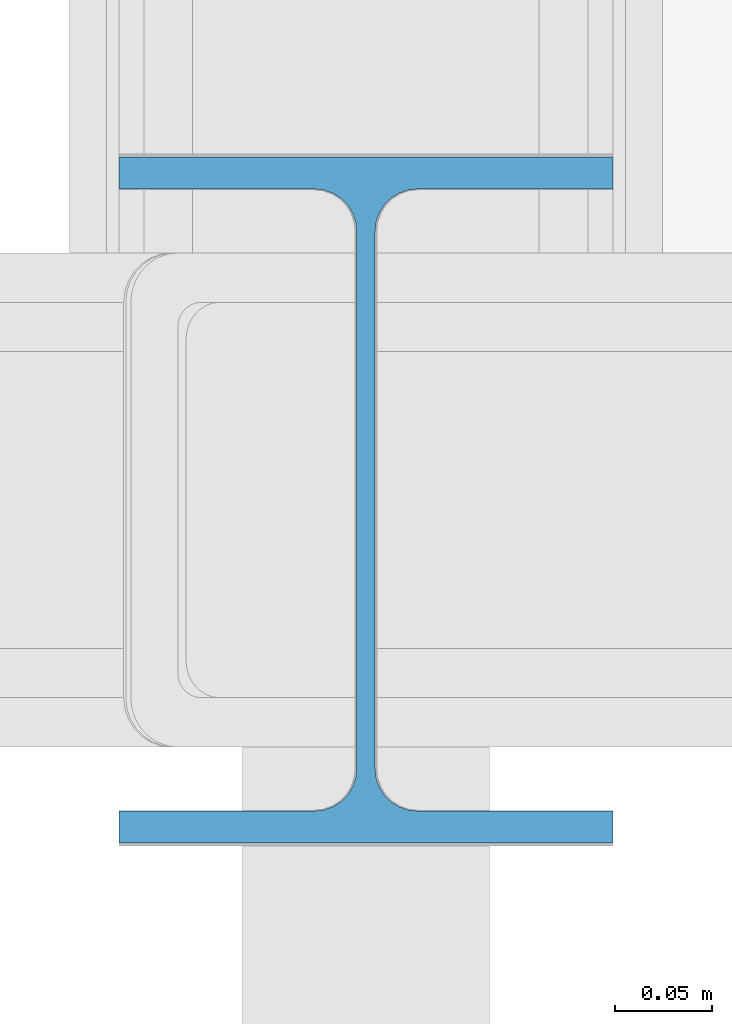
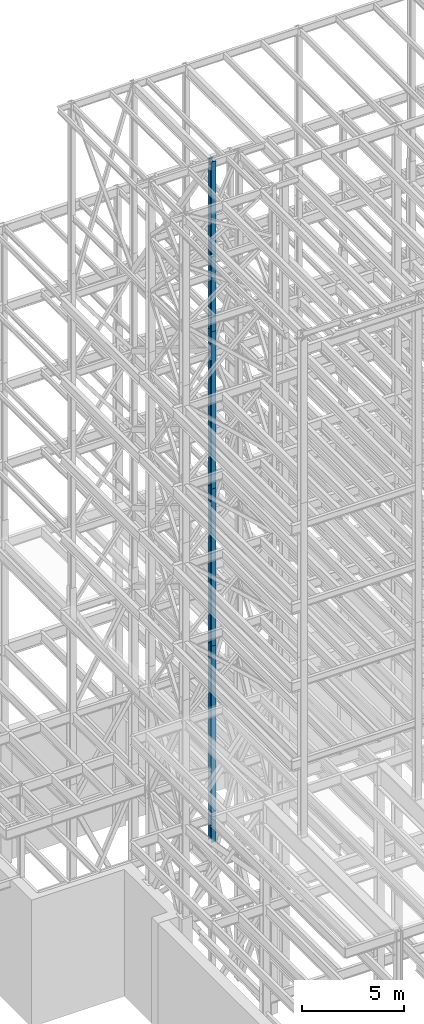
# One storey, part 15 of 150: 4 columns.
"""IFC2X3 building model written with IfcOpenShell, lengths in millimetres."""

from ifc_helpers import new_model, si_unit, frame, origin_with_axes, origin_2d_with_axis, place, context, subcontext, project, spatial, i_section, extrude, material, type_object, element, save


model = new_model("IFC2X3")

# Units and contexts
model_context = context("Model", 3, precision=1e-05, world=origin_with_axes())
body_context = subcontext(model_context, "Body", "Model", "MODEL_VIEW")
ifc_project = project(units=[si_unit("LENGTHUNIT", "METRE", prefix="MILLI"), si_unit("AREAUNIT", "SQUARE_METRE"), si_unit("VOLUMEUNIT", "CUBIC_METRE"), si_unit("MASSUNIT", "GRAM", prefix="KILO"), si_unit("TIMEUNIT", "SECOND"), si_unit("PLANEANGLEUNIT", "RADIAN"), si_unit("SOLIDANGLEUNIT", "STERADIAN"), si_unit("THERMODYNAMICTEMPERATUREUNIT", "DEGREE_CELSIUS"), si_unit("LUMINOUSINTENSITYUNIT", "LUMEN")], contexts=[model_context])

# Site, building, storey
site_placement = place(None, origin_with_axes())
site = spatial("IfcSite", under=ifc_project, at=site_placement, CompositionType="ELEMENT")
building_placement = place(site_placement, origin_with_axes())
building = spatial("IfcBuilding", under=site, at=building_placement, Name="Undefined", CompositionType="ELEMENT")
storey_placement = place(building_placement, origin_with_axes())
storey = spatial("IfcBuildingStorey", under=building, at=storey_placement, Name="Undefined", CompositionType="ELEMENT", Elevation=0.0)

# Columns
ifc_material = material(Name="STEEL/A992")
column_type = type_object("IfcColumnType", Name="W14X61", PredefinedType="NOTDEFINED")
column_1_placement = place(storey_placement, frame((8788.39949708, 24384.0, 55702.2), z_axis=(0.0, 0.0, 1.0), x_axis=(1.0, 0.0, 0.0)))
element("IfcColumn", 1, at=column_1_placement, inside=storey, type_object=column_type, material=ifc_material, Name="COLUMN", ObjectType="W14X61", context=body_context, shape_type="SweptSolid", body=[
    extrude(i_section(OverallWidth=254.0, OverallDepth=352.425, WebThickness=9.5249, FlangeThickness=16.383, FilletRadius=21.717, at=origin_2d_with_axis()), frame((0.0, 0.0, 10210.8), z_axis=(0.0, 0.0, -1.0), x_axis=(-1.0, 0.0, 0.0)), (0.0, 0.0, 1.0), 10210.8),
])
for number, where, z_axis, x_axis, name in (
    (2, (8788.39949708, 24384.0, 46253.4), (0.0, 0.0, 1.0), (1.0, 0.0, 0.0), "COLUMN"),
    (3, (8788.39949708, 24384.0, 36804.6), (0.0, 0.0, 1.0), (1.0, 0.0, 0.0), "COLUMN"),
):
    element("IfcColumn", number, at=place(storey_placement, frame(where, z_axis=z_axis, x_axis=x_axis)), inside=storey, type_object=column_type, material=ifc_material, Name=name, ObjectType="W14X61", context=body_context, shape_type="SweptSolid", body=[
        extrude(i_section(OverallWidth=254.0, OverallDepth=352.425, WebThickness=9.5249, FlangeThickness=16.383, FilletRadius=21.717, at=origin_2d_with_axis()), frame((0.0, 0.0, 9448.8), z_axis=(0.0, 0.0, -1.0), x_axis=(-1.0, 0.0, 0.0)), (0.0, 0.0, 1.0), 9448.8),
    ])
column_2_placement = place(storey_placement, frame((8788.39949708, 24384.0, 24993.6), z_axis=(0.0, 0.0, 1.0), x_axis=(1.0, 0.0, 0.0)))
element("IfcColumn", 4, at=column_2_placement, inside=storey, type_object=column_type, material=ifc_material, Name="COLUMN", ObjectType="W14X61", context=body_context, shape_type="SweptSolid", body=[
    extrude(i_section(OverallWidth=254.0, OverallDepth=352.425, WebThickness=9.5249, FlangeThickness=16.383, FilletRadius=21.717, at=origin_2d_with_axis()), frame((0.0, 0.0, 11811.0), z_axis=(0.0, 0.0, -1.0), x_axis=(-1.0, 0.0, 0.0)), (0.0, 0.0, 1.0), 11811.0),
])

save(model, "model.ifc")
